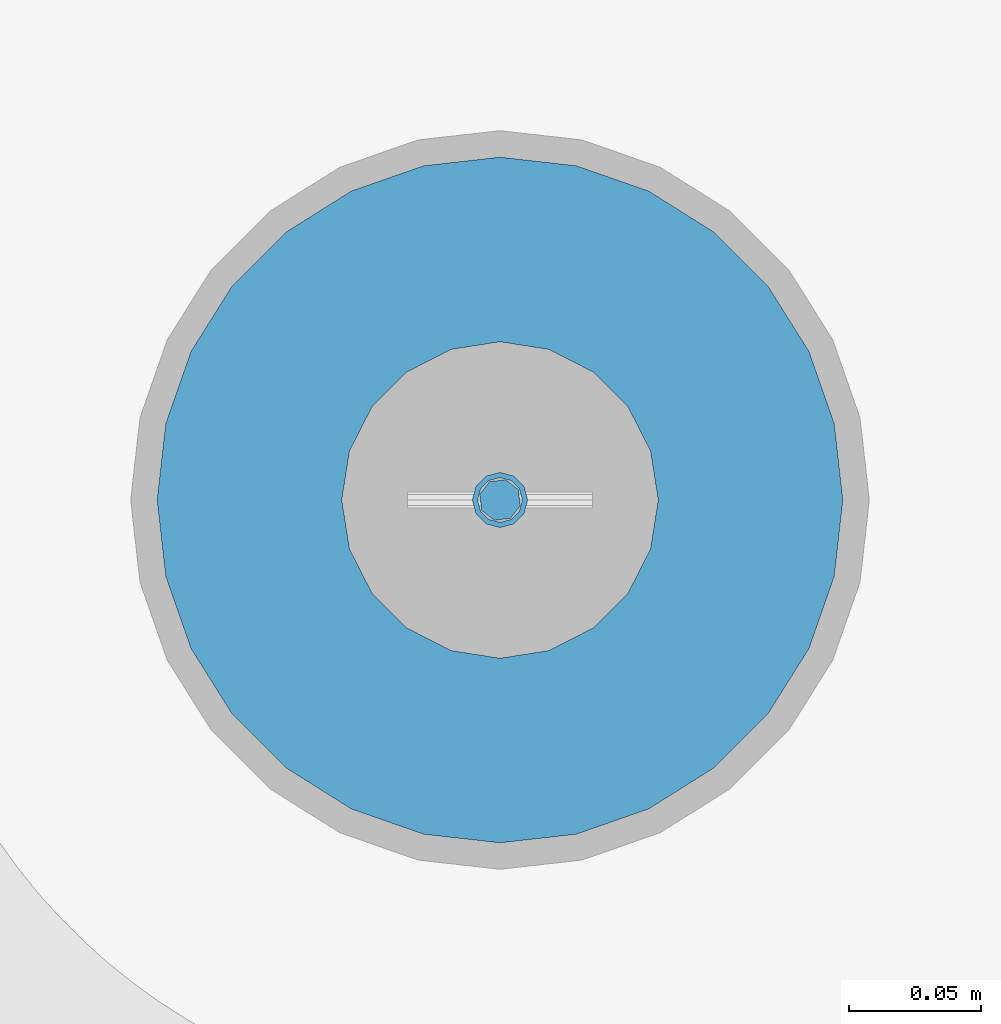
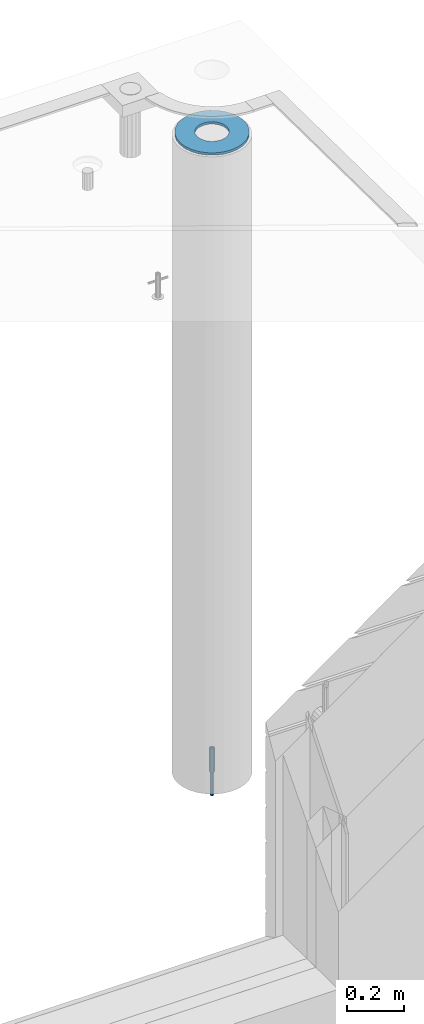
# One storey, part 38 of 350: 3 columns, 3 elements without a shape of their own.
"""IFC2X3 building model written with IfcOpenShell, lengths in millimetres."""

from ifc_helpers import new_model, si_unit, frame, origin_with_axes, place, context, subcontext, project, spatial, faceted_brep, material, type_object, element, aggregate, save


model = new_model("IFC2X3")

# Units and contexts
model_context = context("Model", 3, precision=1e-05, world=origin_with_axes())
body_context = subcontext(model_context, "Body", "Model", "MODEL_VIEW")
ifc_project = project(units=[si_unit("LENGTHUNIT", "METRE", prefix="MILLI"), si_unit("AREAUNIT", "SQUARE_METRE"), si_unit("VOLUMEUNIT", "CUBIC_METRE"), si_unit("MASSUNIT", "GRAM", prefix="KILO"), si_unit("TIMEUNIT", "SECOND"), si_unit("PLANEANGLEUNIT", "RADIAN"), si_unit("SOLIDANGLEUNIT", "STERADIAN"), si_unit("THERMODYNAMICTEMPERATUREUNIT", "DEGREE_CELSIUS"), si_unit("LUMINOUSINTENSITYUNIT", "LUMEN")], contexts=[model_context])

# Site, building, storey
site_placement = place(None, origin_with_axes())
site = spatial("IfcSite", under=ifc_project, at=site_placement, CompositionType="ELEMENT")
building_placement = place(site_placement, origin_with_axes())
building = spatial("IfcBuilding", under=site, at=building_placement, CompositionType="ELEMENT")
storey_placement = place(building_placement, origin_with_axes())
storey = spatial("IfcBuildingStorey", under=building, at=storey_placement, Name="2", CompositionType="ELEMENT", Elevation=0.0)

# Assemblies, columns
assembly_1_placement = place(storey_placement, origin_with_axes())
assembly_1 = element("IfcElementAssembly", 1, at=assembly_1_placement, inside=storey, AssemblyPlace="NOTDEFINED", PredefinedType="REINFORCEMENT_UNIT")
assembly_2_placement = place(assembly_1_placement, origin_with_axes())
assembly_2 = element("IfcElementAssembly", 2, at=assembly_2_placement, Name="Steel Assembly", AssemblyPlace="NOTDEFINED", PredefinedType="RIGID_FRAME")
ifc_material_1 = material(Name="STEEL/S235JR")
column_type_1 = type_object("IfcColumnType", Name="D16", PredefinedType="NOTDEFINED")
column_1_placement = place(assembly_2_placement, frame((35010.0004801435, 22669.9842012047, 84625.0), z_axis=(-0.261346946111888, -0.96524492941325, 0.0), x_axis=(0.0, 0.0, 1.0)))
column_1 = element("IfcColumn", 3, at=column_1_placement, type_object=column_type_1, material=ifc_material_1, Name="M16", ObjectType="D16", context=body_context, shape_type="Brep", body=[
    faceted_brep([(0.0, -8.0, 0.0), (0.0, -5.65685424949334, -5.65685424949334), (150.0, -5.65685424949697, -5.65685424949334), (150.0, -8.00000000000364, 0.0), (0.0, 0.0, -8.0), (150.0, -7.27595761418343e-12, -7.99999999999636), (0.0, 5.65685424949334, -5.65685424949334), (150.0, 5.6568542494897, -5.65685424949334), (0.0, 8.0, 0.0), (150.0, 8.0, -3.63797880709171e-12), (0.0, 5.65685424949334, 5.65685424949334), (150.0, 5.65685424949334, 5.65685424949697), (0.0, 0.0, 8.0), (150.0, -3.63797880709171e-12, 8.0), (0.0, -5.65685424949334, 5.65685424949334), (150.0, -5.65685424949334, 5.6568542494897)], [[[0, 1, 2, 3]], [[1, 4, 5, 2]], [[4, 6, 7, 5]], [[6, 8, 9, 7]], [[8, 10, 11, 9]], [[10, 12, 13, 11]], [[12, 14, 15, 13]], [[14, 0, 3, 15]], [[5, 7, 9, 11, 13, 15, 3, 2]], [[14, 12, 10, 8, 6, 4, 1, 0]]]),
])
aggregate(assembly_2, [column_1])
assembly_3_placement = place(assembly_1_placement, origin_with_axes())
assembly_3 = element("IfcElementAssembly", 4, at=assembly_3_placement, Name="Steel Assembly", AssemblyPlace="NOTDEFINED", PredefinedType="RIGID_FRAME")
ifc_material_2 = material(Name="STEEL/Steel_Undefined")
column_type_2 = type_object("IfcColumnType", PredefinedType="NOTDEFINED")
column_2_placement = place(assembly_3_placement, frame((35009.9987952044, 22669.984888838, 84725.0), z_axis=(0.0, 1.0, 0.0), x_axis=(0.0, 0.0, 1.0)))
column_2 = element("IfcColumn", 5, at=column_2_placement, type_object=column_type_2, material=ifc_material_2, context=body_context, shape_type="Brep", body=[
    faceted_brep([(0.0, -8.49999999999272, -1.45519152283669e-11), (0.0, -7.36121593215648, 4.24999999998545), (100.000000000262, -7.36121593215648, 4.24999999998545), (100.000000000262, -8.49999999999272, -1.45519152283669e-11), (0.0, -4.24999999998545, 7.36121593216376), (100.000000000262, -4.24999999998545, 7.36121593216376), (0.0, 1.45519152283669e-11, 8.49999999998545), (100.000000000262, 1.45519152283669e-11, 8.49999999998545), (0.0, 4.25000000001455, 7.36121593216376), (100.000000000262, 4.25000000001455, 7.36121593216376), (0.0, 7.36121593217104, 4.24999999998545), (100.000000000262, 7.36121593217104, 4.24999999998545), (0.0, 8.50000000000728, 0.0), (100.000000000262, 8.50000000000728, 0.0), (0.0, 7.36121593217104, -4.25000000001455), (100.000000000262, 7.36121593217104, -4.25000000001455), (0.0, 4.25000000000728, -7.36121593219286), (100.000000000262, 4.25000000000728, -7.36121593219286), (0.0, 7.27595761418343e-12, -8.5), (100.000000000262, 7.27595761418343e-12, -8.5), (0.0, -4.24999999999272, -7.36121593217831), (100.000000000262, -4.24999999999272, -7.36121593217831), (0.0, -7.36121593215648, -4.25), (100.000000000262, -7.36121593215648, -4.25), (0.0, -10.4999999999927, -1.45519152283669e-11), (0.0, -9.09326673972828, -5.25000000001455), (100.000000000262, -9.09326673972828, -5.25000000001455), (100.000000000262, -10.4999999999927, -1.45519152283669e-11), (0.0, -5.24999999998545, -9.09326673974283), (100.000000000262, -5.24999999998545, -9.09326673974283), (0.0, 7.27595761418343e-12, -10.5), (100.000000000262, 7.27595761418343e-12, -10.5), (0.0, 5.25000000001455, -9.09326673975738), (100.000000000262, 5.25000000001455, -9.09326673975738), (0.0, 9.09326673975011, -5.25000000001455), (100.000000000262, 9.09326673975011, -5.25000000001455), (0.0, 10.5000000000073, -1.45519152283669e-11), (100.000000000262, 10.5000000000073, -1.45519152283669e-11), (0.0, 9.09326673975011, 5.25), (100.000000000262, 9.09326673975011, 5.25), (0.0, 5.25000000000728, 9.09326673972828), (100.000000000262, 5.25000000000728, 9.09326673972828), (0.0, 1.45519152283669e-11, 10.4999999999854), (100.000000000262, 1.45519152283669e-11, 10.4999999999854), (0.0, -5.24999999999272, 9.09326673972828), (100.000000000262, -5.24999999999272, 9.09326673972828), (0.0, -9.09326673972828, 5.24999999998545), (100.000000000262, -9.09326673972828, 5.24999999998545)], [[[0, 1, 2, 3]], [[1, 4, 5, 2]], [[4, 6, 7, 5]], [[6, 8, 9, 7]], [[8, 10, 11, 9]], [[10, 12, 13, 11]], [[12, 14, 15, 13]], [[14, 16, 17, 15]], [[16, 18, 19, 17]], [[18, 20, 21, 19]], [[20, 22, 23, 21]], [[22, 0, 3, 23]], [[24, 25, 26, 27]], [[25, 28, 29, 26]], [[28, 30, 31, 29]], [[30, 32, 33, 31]], [[32, 34, 35, 33]], [[34, 36, 37, 35]], [[36, 38, 39, 37]], [[38, 40, 41, 39]], [[40, 42, 43, 41]], [[42, 44, 45, 43]], [[44, 46, 47, 45]], [[46, 24, 27, 47]], [[29, 31, 33, 35, 37, 39, 41, 43, 45, 47, 27, 26], [5, 7, 9, 11, 13, 15, 17, 19, 21, 23, 3, 2]], [[46, 44, 42, 40, 38, 36, 34, 32, 30, 28, 25, 24], [22, 20, 18, 16, 14, 12, 10, 8, 6, 4, 1, 0]]]),
])
aggregate(assembly_3, [column_2])
ifc_material_3 = material()
column_type_3 = type_object("IfcColumnType", Name="D260", PredefinedType="NOTDEFINED")
column_3_placement = place(assembly_1_placement, frame((35009.9987952044, 22669.984888838, 87435.0), z_axis=(-1.0, 3.00000001838171e-08, 0.0), x_axis=(0.0, 0.0, 1.0)))
column_3 = element("IfcColumn", 6, at=column_3_placement, type_object=column_type_3, material=ifc_material_3, Name="60", ObjectType="D260", context=body_context, shape_type="Brep", body=[
    faceted_brep([(10.0, -18.541019662498, -57.0633909777098), (0.0, -18.541019662498, -57.0633909777098), (0.0, -35.2671151375471, -48.5410196624944), (10.0, -35.2671151375471, -48.5410196624944), (0.0, -48.541019662498, -35.2671151375471), (10.0, -48.541019662498, -35.2671151375471), (0.0, -57.0633909777098, -18.5410196624944), (10.0, -57.0633909777098, -18.5410196624944), (0.0, -60.0, 0.0), (10.0, -60.0, 0.0), (0.0, -57.0633909777098, 18.5410196624944), (10.0, -57.0633909777098, 18.5410196624944), (0.0, -48.541019662498, 35.2671151375471), (10.0, -48.541019662498, 35.2671151375471), (0.0, -35.2671151375471, 48.5410196624944), (10.0, -35.2671151375471, 48.5410196624944), (0.0, -18.541019662498, 57.0633909777098), (10.0, -18.541019662498, 57.0633909777098), (0.0, 0.0, 60.0), (10.0, 0.0, 60.0), (0.0, 18.541019662498, 57.0633909777098), (10.0, 18.541019662498, 57.0633909777098), (0.0, 35.2671151375471, 48.5410196624944), (10.0, 35.2671151375471, 48.5410196624944), (0.0, 48.541019662498, 35.2671151375471), (10.0, 48.541019662498, 35.2671151375471), (0.0, 57.0633909777098, 18.5410196624944), (10.0, 57.0633909777098, 18.5410196624944), (0.0, 60.0, 0.0), (10.0, 60.0, 0.0), (0.0, 57.0633909777098, -18.5410196624944), (10.0, 57.0633909777098, -18.5410196624944), (0.0, 48.541019662498, -35.2671151375471), (10.0, 48.541019662498, -35.2671151375471), (0.0, 35.2671151375471, -48.5410196624944), (10.0, 35.2671151375471, -48.5410196624944), (0.0, 18.541019662498, -57.0633909777098), (10.0, 18.541019662498, -57.0633909777098), (0.0, 0.0, -60.0), (10.0, 0.0, -60.0), (0.0, -126.740628583637, -28.9277214143222), (0.0, -117.125952827315, -56.4048860852854), (10.0, -117.125952827315, -56.4048860852854), (10.0, -126.740628583637, -28.9277214143222), (0.0, -101.638092720845, -81.0536742416371), (10.0, -101.638092720845, -81.0536742416371), (0.0, -81.0536742416371, -101.638092720845), (10.0, -81.0536742416371, -101.638092720845), (0.0, -56.4048860852818, -117.125952827315), (10.0, -56.4048860852818, -117.125952827315), (0.0, -28.9277214143222, -126.740628583641), (10.0, -28.9277214143222, -126.740628583641), (0.0, 0.0, -130.0), (10.0, 0.0, -130.0), (0.0, 28.9277214143222, -126.740628583641), (10.0, 28.9277214143222, -126.740628583641), (0.0, 56.4048860852818, -117.125952827315), (10.0, 56.4048860852818, -117.125952827315), (0.0, 81.0536742416371, -101.638092720845), (10.0, 81.0536742416371, -101.638092720845), (0.0, 101.638092720845, -81.0536742416371), (10.0, 101.638092720845, -81.0536742416371), (0.0, 117.125952827315, -56.4048860852854), (10.0, 117.125952827315, -56.4048860852854), (0.0, 126.740628583637, -28.9277214143222), (10.0, 126.740628583637, -28.9277214143222), (0.0, 130.0, -1.81898940354586e-12), (10.0, 130.0, 0.0), (0.0, 126.740628583637, 28.9277214143222), (10.0, 126.740628583637, 28.9277214143222), (0.0, 117.125952827315, 56.4048860852854), (10.0, 117.125952827315, 56.4048860852854), (0.0, 101.638092720845, 81.0536742416371), (10.0, 101.638092720845, 81.0536742416371), (0.0, 81.0536742416371, 101.638092720845), (10.0, 81.0536742416371, 101.638092720845), (0.0, 56.4048860852818, 117.125952827315), (10.0, 56.4048860852818, 117.125952827315), (0.0, 28.9277214143222, 126.740628583641), (10.0, 28.9277214143222, 126.740628583641), (0.0, 0.0, 130.0), (10.0, 0.0, 130.0), (0.0, -28.9277214143222, 126.740628583641), (10.0, -28.9277214143222, 126.740628583641), (0.0, -56.4048860852818, 117.125952827315), (10.0, -56.4048860852818, 117.125952827315), (0.0, -81.0536742416371, 101.638092720845), (10.0, -81.0536742416371, 101.638092720845), (0.0, -101.638092720845, 81.0536742416371), (10.0, -101.638092720845, 81.0536742416371), (0.0, -117.125952827315, 56.4048860852854), (10.0, -117.125952827315, 56.4048860852854), (0.0, -126.740628583637, 28.9277214143222), (10.0, -126.740628583637, 28.9277214143222), (0.0, -130.0, -3.63797880709171e-12), (10.0, -130.0, 0.0)], [[[0, 1, 2, 3]], [[3, 2, 4, 5]], [[5, 4, 6, 7]], [[7, 6, 8, 9]], [[9, 8, 10, 11]], [[11, 10, 12, 13]], [[13, 12, 14, 15]], [[15, 14, 16, 17]], [[17, 16, 18, 19]], [[19, 18, 20, 21]], [[21, 20, 22, 23]], [[23, 22, 24, 25]], [[25, 24, 26, 27]], [[27, 26, 28, 29]], [[29, 28, 30, 31]], [[31, 30, 32, 33]], [[33, 32, 34, 35]], [[35, 34, 36, 37]], [[37, 36, 38, 39]], [[39, 38, 1, 0]], [[40, 41, 42, 43]], [[41, 44, 45, 42]], [[44, 46, 47, 45]], [[46, 48, 49, 47]], [[48, 50, 51, 49]], [[50, 52, 53, 51]], [[52, 54, 55, 53]], [[54, 56, 57, 55]], [[56, 58, 59, 57]], [[58, 60, 61, 59]], [[60, 62, 63, 61]], [[62, 64, 65, 63]], [[64, 66, 67, 65]], [[66, 68, 69, 67]], [[68, 70, 71, 69]], [[70, 72, 73, 71]], [[72, 74, 75, 73]], [[74, 76, 77, 75]], [[76, 78, 79, 77]], [[78, 80, 81, 79]], [[80, 82, 83, 81]], [[82, 84, 85, 83]], [[84, 86, 87, 85]], [[86, 88, 89, 87]], [[88, 90, 91, 89]], [[90, 92, 93, 91]], [[92, 94, 95, 93]], [[42, 45, 47, 49, 51, 53, 55, 57, 59, 61, 63, 65, 67, 69, 71, 73, 75, 77, 79, 81, 83, 85, 87, 89, 91, 93, 95, 43], [3, 5, 7, 9, 11, 13, 15, 17, 19, 21, 23, 25, 27, 29, 31, 33, 35, 37, 39, 0]], [[94, 40, 43, 95]], [[92, 90, 88, 86, 84, 82, 80, 78, 76, 74, 72, 70, 68, 66, 64, 62, 60, 58, 56, 54, 52, 50, 48, 46, 44, 41, 40, 94], [34, 32, 30, 28, 26, 24, 22, 20, 18, 16, 14, 12, 10, 8, 6, 4, 2, 1, 38, 36]]]),
])
aggregate(assembly_1, [assembly_3, assembly_2, column_3])

save(model, "model.ifc")
